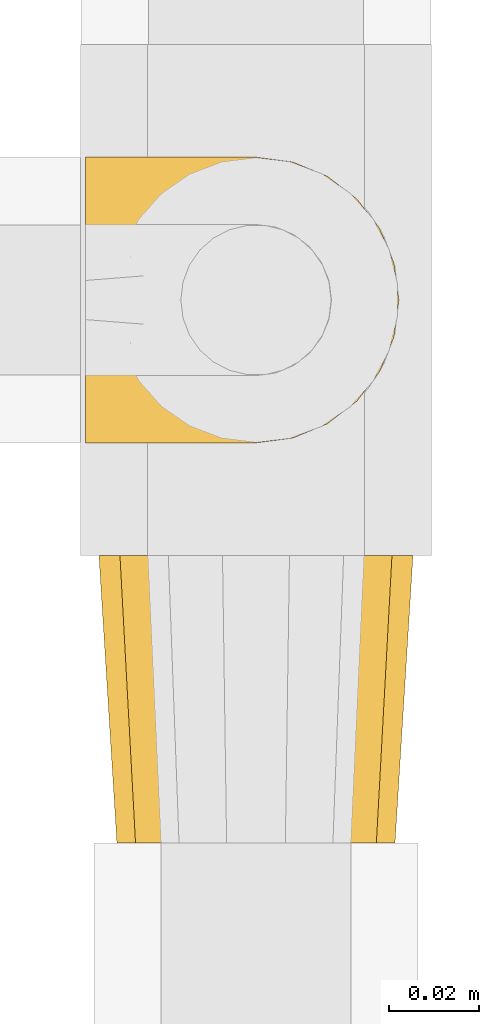
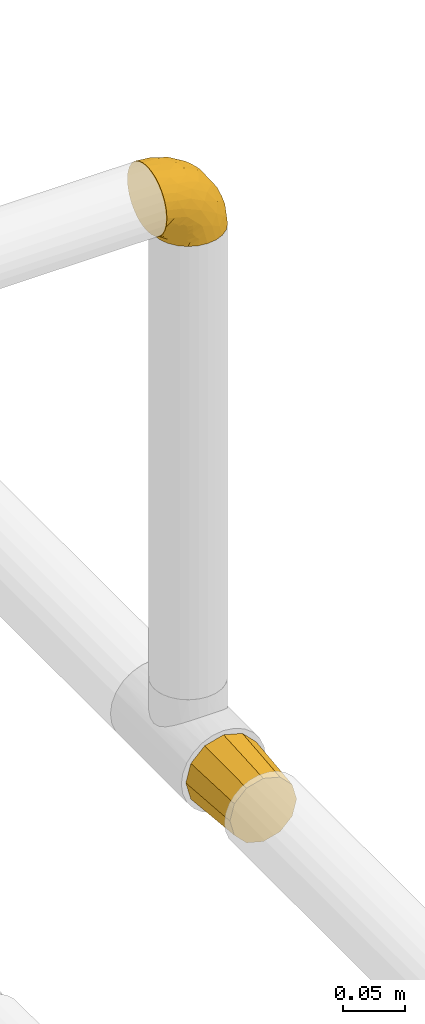
# One storey, part 15 of 39: 2 coverings.
"""IFC2X3 building model written with IfcOpenShell, lengths in millimetres."""

from ifc_helpers import new_model, entity, si_unit, converted_unit, derived_unit, direction, frame, origin, place, context, subcontext, project, spatial, faceted_brep, element, save


model = new_model("IFC2X3")

# Units and contexts
model_context = context("Model", 3, precision=0.01, world=origin(), true_north=direction((6.12303176911189e-17, 1.0)))
body_context = subcontext(model_context, "Body", "Model", "MODEL_VIEW")
ifc_project = project(units=[si_unit("LENGTHUNIT", "METRE", prefix="MILLI"), si_unit("AREAUNIT", "SQUARE_METRE"), si_unit("VOLUMEUNIT", "CUBIC_METRE"), converted_unit("PLANEANGLEUNIT", "DEGREE", entity("IfcRatioMeasure", 0.0174532925199433), si_unit("PLANEANGLEUNIT", "RADIAN"), dimensions=[0, 0, 0, 0, 0, 0, 0]), si_unit("MASSUNIT", "GRAM", prefix="KILO"), derived_unit("MASSDENSITYUNIT", [(si_unit("MASSUNIT", "GRAM", prefix="KILO"), 1), (si_unit("LENGTHUNIT", "METRE"), -3)]), derived_unit("MOMENTOFINERTIAUNIT", [(si_unit("LENGTHUNIT", "METRE"), 4)]), si_unit("TIMEUNIT", "SECOND"), si_unit("FREQUENCYUNIT", "HERTZ"), si_unit("THERMODYNAMICTEMPERATUREUNIT", "DEGREE_CELSIUS"), derived_unit("THERMALTRANSMITTANCEUNIT", [(si_unit("MASSUNIT", "GRAM", prefix="KILO"), 1), (si_unit("THERMODYNAMICTEMPERATUREUNIT", "KELVIN"), -1), (si_unit("TIMEUNIT", "SECOND"), -3)]), derived_unit("VOLUMETRICFLOWRATEUNIT", [(si_unit("LENGTHUNIT", "METRE"), 3), (si_unit("TIMEUNIT", "SECOND"), -1)]), derived_unit("MASSFLOWRATEUNIT", [(si_unit("MASSUNIT", "GRAM", prefix="KILO"), 1), (si_unit("TIMEUNIT", "SECOND"), -1)]), derived_unit("ROTATIONALFREQUENCYUNIT", [(si_unit("TIMEUNIT", "SECOND"), -1)]), si_unit("ELECTRICCURRENTUNIT", "AMPERE"), si_unit("ELECTRICVOLTAGEUNIT", "VOLT"), si_unit("POWERUNIT", "WATT"), si_unit("FORCEUNIT", "NEWTON", prefix="KILO"), si_unit("ILLUMINANCEUNIT", "LUX"), si_unit("LUMINOUSFLUXUNIT", "LUMEN"), si_unit("LUMINOUSINTENSITYUNIT", "CANDELA"), derived_unit("USERDEFINED", [(si_unit("MASSUNIT", "GRAM", prefix="KILO"), -1), (si_unit("LENGTHUNIT", "METRE"), -2), (si_unit("TIMEUNIT", "SECOND"), 3), (si_unit("LUMINOUSFLUXUNIT", "LUMEN"), 1)]), derived_unit("LINEARVELOCITYUNIT", [(si_unit("LENGTHUNIT", "METRE"), 1), (si_unit("TIMEUNIT", "SECOND"), -1)]), si_unit("PRESSUREUNIT", "PASCAL"), derived_unit("USERDEFINED", [(si_unit("LENGTHUNIT", "METRE"), -2), (si_unit("MASSUNIT", "GRAM", prefix="KILO"), 1), (si_unit("TIMEUNIT", "SECOND"), -2)]), derived_unit("LINEARFORCEUNIT", [(si_unit("MASSUNIT", "GRAM", prefix="KILO"), 1), (si_unit("LENGTHUNIT", "METRE"), 1), (si_unit("TIMEUNIT", "SECOND"), -2), (si_unit("LENGTHUNIT", "METRE"), -1)]), derived_unit("PLANARFORCEUNIT", [(si_unit("MASSUNIT", "GRAM", prefix="KILO"), 1), (si_unit("LENGTHUNIT", "METRE"), 1), (si_unit("TIMEUNIT", "SECOND"), -2), (si_unit("LENGTHUNIT", "METRE"), -2)])], contexts=[model_context])

# Site, building, storey
site_placement = place(None, origin())
site = spatial("IfcSite", under=ifc_project, at=site_placement, CompositionType="ELEMENT")
building_placement = place(site_placement, origin())
building = spatial("IfcBuilding", under=site, at=building_placement, CompositionType="ELEMENT")
storey_placement = place(building_placement, frame((0.0, 0.0, 24000.0)))
storey = spatial("IfcBuildingStorey", under=building, at=storey_placement, Name="07", CompositionType="ELEMENT", Elevation=24000.0)

# Coverings
covering_1_placement = place(storey_placement, frame((31390.4, 8376.51, 3160.4)))
element("IfcCovering", 1, at=covering_1_placement, inside=storey, Name=":ADSK_", ObjectType=":ADSK_", PredefinedType="INSULATION", context=body_context, shape_type="Brep", body=[
    faceted_brep([(1.6, 26.36, 70.65), (1.6, 33.45, 71.45), (1.6, 40.54, 70.65), (1.6, 47.27, 68.29), (1.6, 53.31, 64.49), (1.6, 58.35, 59.45), (1.6, 62.14, 53.41), (1.6, 64.5, 46.68), (1.6, 65.3, 39.6), (1.6, 64.86, 35.69), (1.6, 64.5, 32.5), (1.6, 63.32, 29.14), (1.6, 62.14, 25.77), (1.6, 58.34, 19.73), (1.6, 53.3, 14.69), (1.6, 47.26, 10.9), (1.6, 40.53, 8.54), (1.6, 33.45, 7.75), (1.6, 26.35, 8.54), (1.6, 19.62, 10.9), (1.6, 13.58, 14.7), (1.6, 8.54, 19.74), (1.6, 4.75, 25.78), (1.6, 3.57, 29.15), (1.6, 2.39, 32.51), (1.6, 2.03, 35.69), (1.6, 1.81, 37.64), (1.6, 1.6, 39.6), (1.6, 2.39, 46.69), (1.6, 4.75, 53.42), (1.6, 8.55, 59.46), (1.6, 13.59, 64.5), (1.6, 19.63, 68.29), (23.67, 61.03, 1.6), (27.51, 62.62, 1.6), (31.35, 64.21, 1.6), (35.67, 64.78, 1.6), (37.63, 65.04, 1.6), (39.6, 65.3, 1.6), (47.84, 64.21, 1.6), (55.52, 61.03, 1.6), (62.12, 55.97, 1.6), (67.18, 49.37, 1.6), (70.36, 41.69, 1.6), (71.45, 33.45, 1.6), (70.36, 25.2, 1.6), (67.18, 17.52, 1.6), (62.12, 10.92, 1.6), (55.52, 5.86, 1.6), (47.84, 2.68, 1.6), (39.6, 1.6, 1.6), (35.67, 2.11, 1.6), (31.35, 2.68, 1.6), (27.51, 4.27, 1.6), (23.67, 5.86, 1.6), (20.37, 8.39, 1.6), (17.07, 10.92, 1.6), (12.01, 17.52, 1.6), (8.83, 25.2, 1.6), (7.75, 33.45, 1.6), (8.83, 41.69, 1.6), (12.01, 49.37, 1.6), (17.07, 55.97, 1.6), (20.37, 58.5, 1.6), (33.94, 2.87, 35.56), (20.6, 1.6, 34.5), (24.07, 1.6, 31.03), (27.55, 1.6, 27.55), (31.03, 1.6, 24.07), (34.5, 1.6, 20.6), (68.79, 33.45, 14.96), (53.62, 10.76, 32.2), (50.17, 5.89, 25.13), (58.62, 9.64, 17.37), (67.51, 22.45, 17.86), (61.03, 16.56, 27.91), (64.5, 15.17, 13.85), (17.98, 12.49, 61.37), (61.71, 25.02, 34.87), (52.25, 18.64, 44.22), (16.72, 2.29, 43.56), (39.09, 6.11, 40.93), (25.86, 5.18, 48.36), (44.07, 2.43, 17.22), (44.36, 11.11, 44.67), (31.35, 26.19, 63.86), (17.72, 24.02, 68.09), (29.45, 19.02, 61.87), (52.37, 4.77, 12.15), (35.28, 1.6, 17.69), (36.06, 1.6, 14.79), (36.84, 1.6, 11.89), (37.61, 1.6, 8.99), (38.11, 1.6, 7.14), (38.61, 1.6, 5.29), (14.07, 7.57, 56.77), (13.65, 17.54, 66.08), (14.96, 33.45, 68.79), (13.32, 4.36, 51.2), (3.44, 1.6, 39.1), (5.29, 1.6, 38.61), (8.99, 1.6, 37.61), (11.89, 1.6, 36.84), (14.79, 1.6, 36.06), (17.69, 1.6, 35.28), (29.19, 9.86, 54.2), (28.91, 14.05, 58.65), (68.17, 28.37, 21.36), (28.33, 33.45, 66.13), (53.45, 25.8, 46.99), (58.56, 33.45, 39.66), (50.99, 33.45, 50.99), (43.14, 22.54, 55.34), (39.23, 15.6, 53.83), (66.13, 33.45, 28.33), (45.6, 28.45, 55.34), (39.66, 33.45, 58.56), (18.04, 9.47, 6.06), (22.76, 5.83, 8.03), (21.95, 5.65, 11.06), (32.18, 2.31, 8.19), (29.08, 2.89, 10.89), (20.77, 2.68, 24.37), (4.75, 22.04, 9.23), (11.03, 5.47, 22.33), (6.78, 5.05, 24.59), (5.68, 7.86, 20.19), (7.71, 25.25, 5.45), (4.42, 28.09, 7.56), (5.94, 33.45, 5.94), (14.52, 12.77, 6.36), (11.63, 2.62, 29.84), (6.6, 3.56, 28.12), (7.33, 11.92, 14.94), (12.48, 11.98, 11.12), (7.99, 17.45, 9.87), (11.14, 17.1, 6.36), (14.07, 7.66, 16.34), (15.37, 4.47, 22.18), (10.81, 7.62, 18.62), (7.89, 2.29, 32.34), (26.18, 3.16, 15.29), (5.8, 16.64, 11.7), (9.94, 12.23, 13.14), (22.23, 4.54, 15.04), (18.39, 7.84, 10.61), (17.71, 2.55, 27.21), (16.87, 7.37, 14.05), (13.24, 3.18, 27.14), (24.95, 4.97, 5.74), (26.59, 2.38, 19.92), (26.16, 1.99, 23.61), (22.11, 3.56, 19.14), (17.43, 4.66, 20.12), (4.75, 44.85, 9.23), (5.8, 50.24, 11.69), (7.99, 49.43, 9.87), (14.07, 59.23, 16.33), (10.06, 54.76, 13.17), (11.54, 59.54, 18.65), (7.71, 41.64, 5.45), (7.89, 64.6, 32.33), (8.99, 65.3, 37.61), (11.89, 65.3, 36.84), (14.79, 65.3, 36.06), (4.42, 38.79, 7.56), (22.42, 62.38, 14.85), (27.95, 64.44, 17.26), (22.22, 61.27, 10.58), (39.1, 65.3, 3.44), (36.84, 65.3, 11.89), (37.61, 65.3, 8.99), (38.61, 65.3, 5.29), (21.49, 59.93, 5.65), (26.52, 62.73, 6.88), (18.09, 60.51, 14.93), (18.39, 59.05, 10.6), (13.88, 56.02, 11.09), (11.14, 49.79, 6.36), (32.18, 64.58, 8.19), (34.5, 65.3, 20.6), (31.03, 65.3, 24.07), (11.65, 64.27, 29.86), (5.67, 59.01, 20.16), (6.81, 61.84, 24.58), (5.29, 65.3, 38.61), (7.14, 65.3, 38.11), (7.34, 54.97, 14.93), (36.06, 65.3, 14.79), (31.38, 64.66, 12.32), (19.83, 63.94, 23.91), (27.55, 65.3, 27.55), (22.94, 63.6, 19.33), (6.6, 63.33, 28.11), (17.93, 57.32, 6.0), (14.52, 54.15, 6.44), (17.45, 64.5, 28.13), (11.03, 61.42, 22.32), (17.69, 65.3, 35.28), (20.6, 65.3, 34.5), (12.33, 63.43, 26.65), (30.27, 64.69, 15.34), (35.28, 65.3, 17.69), (25.9, 62.87, 10.31), (24.07, 65.3, 31.03), (58.62, 57.25, 17.37), (13.32, 62.54, 51.19), (16.72, 64.6, 43.56), (44.07, 64.46, 17.22), (61.71, 41.87, 34.87), (67.51, 44.44, 17.86), (61.03, 50.33, 27.92), (50.18, 61.0, 25.12), (33.92, 64.03, 35.57), (39.08, 60.79, 40.93), (53.62, 56.13, 32.19), (68.17, 38.52, 21.36), (52.37, 62.12, 12.15), (64.5, 51.72, 13.85), (25.86, 61.71, 48.35), (14.07, 59.33, 56.76), (29.18, 57.04, 54.19), (29.46, 47.88, 61.86), (17.73, 42.88, 68.09), (31.37, 40.71, 63.85), (17.99, 54.41, 61.36), (53.45, 41.09, 47.0), (39.25, 51.29, 53.81), (28.92, 52.85, 58.64), (13.65, 49.36, 66.07), (52.23, 48.25, 44.24), (43.13, 44.35, 55.34), (44.36, 55.79, 44.67), (45.6, 38.44, 55.34)], [[[0, 1, 2, 3, 4, 5, 6, 7, 8, 9, 10, 11, 12, 13, 14, 15, 16, 17, 18, 19, 20, 21, 22, 23, 24, 25, 26, 27, 28, 29, 30, 31, 32]], [[33, 34, 35, 36, 37, 38, 39, 40, 41, 42, 43, 44, 45, 46, 47, 48, 49, 50, 51, 52, 53, 54, 55, 56, 57, 58, 59, 60, 61, 62, 63]], [[64, 65, 66, 67, 68, 69]], [[45, 44, 70]], [[71, 72, 73]], [[74, 75, 76]], [[77, 31, 30]], [[75, 78, 79]], [[27, 80, 28]], [[74, 46, 45]], [[64, 81, 82]], [[46, 76, 47]], [[83, 50, 49]], [[48, 47, 73]], [[71, 79, 84]], [[85, 86, 87]], [[49, 48, 88]], [[83, 69, 89, 90, 91, 92, 93, 94, 50]], [[95, 77, 30]], [[75, 74, 78]], [[87, 86, 96]], [[96, 86, 32]], [[96, 32, 31]], [[0, 86, 97]], [[83, 64, 69]], [[98, 80, 82]], [[73, 72, 88]], [[64, 80, 65]], [[1, 0, 97]], [[80, 27, 99, 100, 101, 102, 103, 104, 65]], [[77, 105, 106]], [[64, 82, 80]], [[70, 107, 45]], [[77, 95, 105]], [[82, 95, 98]], [[95, 30, 29]], [[74, 107, 78]], [[86, 0, 32]], [[72, 71, 81]], [[85, 108, 86]], [[76, 73, 47]], [[71, 84, 81]], [[109, 110, 111]], [[87, 112, 85]], [[79, 109, 112]], [[79, 112, 113]], [[88, 83, 49]], [[64, 83, 72]], [[31, 77, 96]], [[87, 96, 77]], [[98, 95, 29]], [[105, 95, 82]], [[81, 105, 82]], [[105, 84, 113]], [[29, 28, 98]], [[114, 107, 70]], [[80, 98, 28]], [[73, 75, 71]], [[79, 71, 75]], [[74, 76, 46]], [[73, 76, 75]], [[78, 107, 114]], [[45, 107, 74]], [[87, 113, 112]], [[115, 85, 112]], [[109, 79, 78]], [[113, 87, 106]], [[116, 115, 111]], [[116, 108, 85]], [[79, 113, 84]], [[109, 78, 110]], [[115, 109, 111]], [[85, 115, 116]], [[109, 115, 112]], [[72, 81, 64]], [[105, 81, 84]], [[73, 88, 48]], [[83, 88, 72]], [[86, 108, 97]], [[78, 114, 110]], [[113, 106, 105]], [[87, 77, 106]], [[117, 118, 119]], [[52, 120, 54, 53]], [[91, 120, 52]], [[91, 90, 120]], [[90, 121, 120]], [[122, 67, 66]], [[18, 123, 19]], [[124, 125, 126]], [[127, 59, 58]], [[128, 129, 127]], [[130, 57, 117]], [[131, 132, 125]], [[19, 133, 20]], [[128, 18, 17]], [[134, 135, 136]], [[137, 138, 139]], [[131, 103, 140]], [[22, 140, 23]], [[131, 65, 104, 103]], [[99, 27, 26, 25, 24, 101, 100]], [[141, 118, 121]], [[19, 123, 142]], [[52, 51, 50, 94, 93, 92, 91]], [[129, 128, 17]], [[117, 56, 118]], [[135, 134, 143]], [[139, 126, 133]], [[119, 144, 145]], [[127, 135, 123]], [[136, 58, 57]], [[101, 24, 23]], [[124, 138, 146]], [[140, 101, 23]], [[145, 147, 134]], [[140, 132, 131]], [[140, 103, 102, 101]], [[140, 22, 132]], [[146, 148, 124]], [[121, 69, 141]], [[55, 149, 118]], [[150, 151, 152]], [[147, 137, 134]], [[144, 150, 152]], [[152, 151, 122]], [[138, 122, 146]], [[59, 127, 129]], [[123, 18, 128]], [[58, 136, 127]], [[135, 127, 136]], [[121, 90, 89, 69]], [[120, 121, 149]], [[122, 66, 146]], [[153, 122, 138]], [[141, 69, 68]], [[127, 123, 128]], [[123, 135, 142]], [[143, 142, 135]], [[19, 142, 133]], [[66, 65, 146]], [[148, 65, 131]], [[22, 21, 132]], [[125, 132, 21]], [[126, 125, 21]], [[148, 125, 124]], [[21, 20, 126]], [[133, 126, 20]], [[139, 138, 124]], [[153, 138, 137]], [[126, 139, 124]], [[139, 133, 143]], [[147, 153, 137]], [[152, 122, 153]], [[134, 136, 130]], [[137, 139, 143]], [[144, 147, 145]], [[153, 147, 152]], [[65, 148, 146]], [[125, 148, 131]], [[141, 144, 119]], [[55, 54, 149]], [[137, 143, 134]], [[142, 143, 133]], [[130, 117, 145]], [[57, 56, 117]], [[134, 130, 145]], [[57, 130, 136]], [[150, 144, 141]], [[147, 144, 152]], [[141, 68, 150]], [[151, 68, 67]], [[117, 119, 145]], [[141, 119, 118]], [[68, 151, 150]], [[122, 151, 67]], [[118, 56, 55]], [[120, 149, 54]], [[118, 149, 121]], [[154, 155, 156]], [[157, 158, 159]], [[129, 160, 59]], [[161, 162, 163, 164]], [[165, 160, 129]], [[166, 167, 168]], [[169, 38, 37, 36, 35, 170, 171, 172]], [[63, 173, 174]], [[175, 176, 177]], [[60, 178, 61]], [[179, 35, 34, 33]], [[160, 60, 59]], [[180, 167, 181]], [[129, 17, 165]], [[182, 161, 164]], [[183, 13, 184]], [[9, 8, 185, 186, 162, 10]], [[187, 155, 15]], [[188, 179, 189]], [[187, 15, 14]], [[190, 191, 192]], [[182, 193, 161]], [[194, 176, 168]], [[176, 195, 177]], [[196, 190, 197]], [[11, 10, 162]], [[11, 161, 12]], [[187, 14, 183]], [[12, 161, 193]], [[156, 158, 177]], [[165, 17, 16]], [[194, 195, 176]], [[187, 159, 158]], [[179, 174, 189]], [[182, 164, 198, 199]], [[200, 199, 196]], [[193, 184, 13]], [[194, 168, 173]], [[201, 202, 189]], [[16, 154, 165]], [[160, 156, 178]], [[160, 165, 154]], [[178, 60, 160]], [[170, 35, 179]], [[188, 170, 179]], [[189, 174, 203]], [[174, 179, 33]], [[201, 189, 203]], [[181, 192, 191]], [[167, 180, 201]], [[192, 175, 190]], [[159, 190, 157]], [[15, 154, 16]], [[204, 196, 199]], [[204, 191, 190]], [[160, 154, 156]], [[15, 155, 154]], [[158, 155, 187]], [[203, 173, 168]], [[192, 181, 167]], [[190, 196, 204]], [[200, 196, 197]], [[184, 193, 182]], [[13, 12, 193]], [[200, 184, 182]], [[184, 200, 183]], [[187, 183, 197]], [[14, 13, 183]], [[162, 161, 11]], [[63, 62, 173]], [[174, 33, 63]], [[173, 62, 194]], [[174, 173, 203]], [[62, 61, 194]], [[195, 61, 178]], [[61, 195, 194]], [[177, 195, 178]], [[156, 177, 178]], [[175, 192, 166]], [[166, 168, 176]], [[167, 203, 168]], [[175, 166, 176]], [[167, 166, 192]], [[177, 157, 175]], [[190, 175, 157]], [[187, 197, 159]], [[190, 159, 197]], [[177, 158, 157]], [[155, 158, 156]], [[167, 201, 203]], [[200, 197, 183]], [[202, 201, 180]], [[202, 188, 189]], [[199, 200, 182]], [[41, 40, 205]], [[206, 207, 7]], [[208, 38, 169, 172, 171, 170, 188, 202, 180]], [[209, 210, 211]], [[212, 213, 214]], [[212, 215, 205]], [[43, 210, 216]], [[217, 40, 39]], [[216, 114, 70]], [[208, 213, 212]], [[205, 40, 217]], [[218, 42, 41]], [[216, 209, 114]], [[42, 218, 210]], [[214, 213, 219]], [[219, 220, 221]], [[199, 207, 213]], [[213, 207, 219]], [[8, 7, 207]], [[222, 223, 224]], [[4, 225, 5]], [[2, 97, 223]], [[110, 226, 111]], [[225, 220, 5]], [[227, 221, 228]], [[223, 229, 3]], [[2, 223, 3]], [[230, 231, 226]], [[224, 223, 108]], [[42, 210, 43]], [[230, 209, 211]], [[222, 225, 229]], [[38, 208, 39]], [[3, 229, 4]], [[213, 180, 181, 191, 204, 199]], [[220, 206, 6]], [[5, 220, 6]], [[207, 199, 198, 164, 163, 162, 186, 185, 8]], [[212, 214, 215]], [[218, 205, 211]], [[211, 215, 230]], [[226, 110, 209]], [[222, 231, 227]], [[222, 224, 231]], [[213, 208, 180]], [[217, 208, 212]], [[222, 229, 223]], [[225, 4, 229]], [[221, 220, 225]], [[206, 220, 219]], [[228, 221, 225]], [[214, 221, 232]], [[207, 206, 219]], [[44, 43, 70]], [[7, 6, 206]], [[230, 215, 232]], [[211, 205, 215]], [[205, 218, 41]], [[210, 218, 211]], [[43, 216, 70]], [[209, 216, 210]], [[233, 116, 111]], [[230, 232, 227]], [[224, 116, 233]], [[230, 226, 209]], [[224, 108, 116]], [[230, 227, 231]], [[221, 227, 232]], [[233, 226, 231]], [[225, 222, 228]], [[226, 233, 111]], [[224, 233, 231]], [[221, 214, 219]], [[214, 232, 215]], [[208, 217, 39]], [[205, 217, 212]], [[97, 2, 1]], [[97, 108, 223]], [[110, 114, 209]], [[227, 228, 222]]]),
])
covering_2_placement = place(storey_placement, frame((31393.4, 8288.96, 2623.4)))
element("IfcCovering", 2, at=covering_2_placement, inside=storey, Name=":ADSK_", ObjectType=":ADSK_", PredefinedType="INSULATION", context=body_context, shape_type="Brep", body=[
    faceted_brep([(21.1, 0.0, 63.44), (15.42, 0.0, 57.77), (9.75, 0.0, 52.1), (7.67, 0.0, 44.35), (5.6, 0.0, 36.6), (7.67, 0.0, 28.85), (9.75, 0.0, 21.1), (15.42, 0.0, 15.42), (21.1, 0.0, 9.75), (28.85, 0.0, 7.67), (36.6, 0.0, 5.6), (44.35, 0.0, 7.67), (52.1, 0.0, 9.75), (57.77, 0.0, 15.42), (63.44, 0.0, 21.1), (65.52, 0.0, 28.85), (67.6, 0.0, 36.6), (65.52, 0.0, 44.35), (63.44, 0.0, 52.1), (57.77, 0.0, 57.77), (52.1, 0.0, 63.44), (44.35, 0.0, 65.52), (36.6, 0.0, 67.6), (28.85, 0.0, 65.52), (69.15, 64.0, 45.72), (71.6, 64.0, 36.6), (69.15, 64.0, 27.47), (66.91, 64.0, 19.1), (60.5, 64.0, 12.69), (54.1, 64.0, 6.28), (45.72, 64.0, 4.04), (36.6, 64.0, 1.6), (27.47, 64.0, 4.04), (19.1, 64.0, 6.28), (12.69, 64.0, 12.69), (6.28, 64.0, 19.1), (4.04, 64.0, 27.47), (1.6, 64.0, 36.6), (4.04, 64.0, 45.72), (6.28, 64.0, 54.1), (12.69, 64.0, 60.5), (19.1, 64.0, 66.91), (27.47, 64.0, 69.15), (36.6, 64.0, 71.6), (45.72, 64.0, 69.15), (54.1, 64.0, 66.91), (60.5, 64.0, 60.5), (66.91, 64.0, 54.1)], [[[0, 1, 2, 3, 4, 5, 6, 7, 8, 9, 10, 11, 12, 13, 14, 15, 16, 17, 18, 19, 20, 21, 22, 23]], [[24, 25, 26, 27, 28, 29, 30, 31, 32, 33, 34, 35, 36, 37, 38, 39, 40, 41, 42, 43, 44, 45, 46, 47]], [[20, 45, 44, 43, 22, 21]], [[47, 46, 45, 20, 19, 18]], [[17, 16, 25, 24, 47, 18]], [[2, 39, 38, 37, 4, 3]], [[41, 40, 39, 2, 1, 0]], [[23, 22, 43, 42, 41, 0]], [[8, 33, 32, 31, 10, 9]], [[35, 34, 33, 8, 7, 6]], [[5, 4, 37, 36, 35, 6]], [[14, 27, 26, 25, 16, 15]], [[29, 28, 27, 14, 13, 12]], [[11, 10, 31, 30, 29, 12]]]),
])

save(model, "model.ifc")
